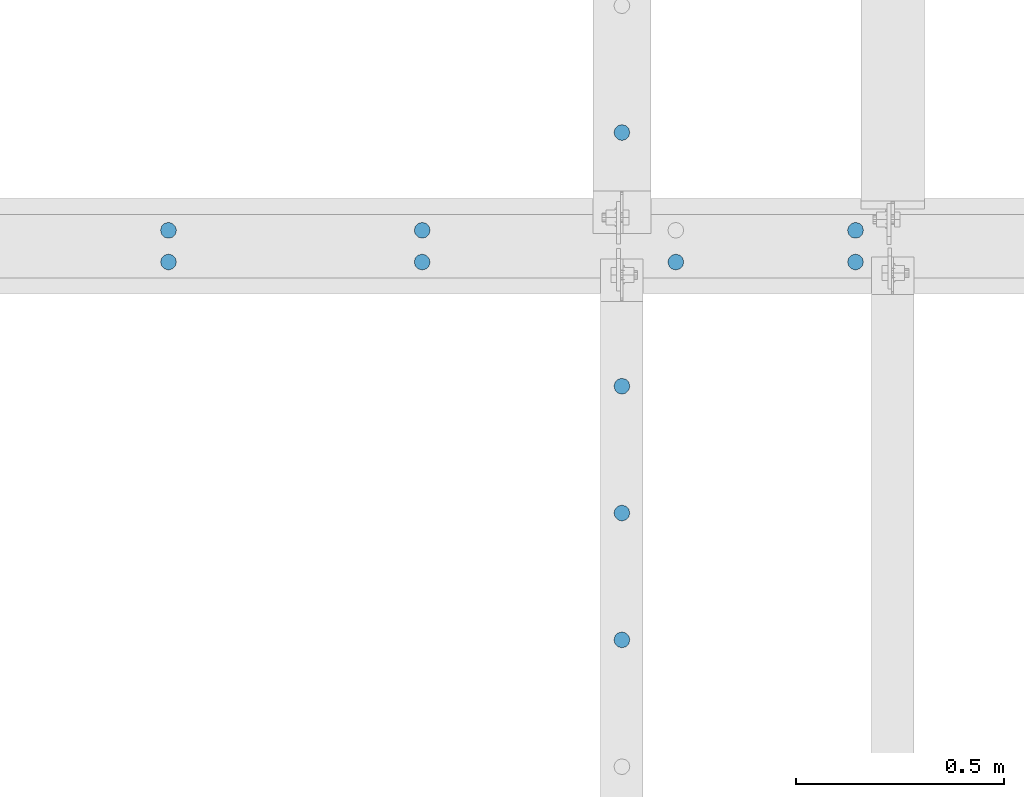
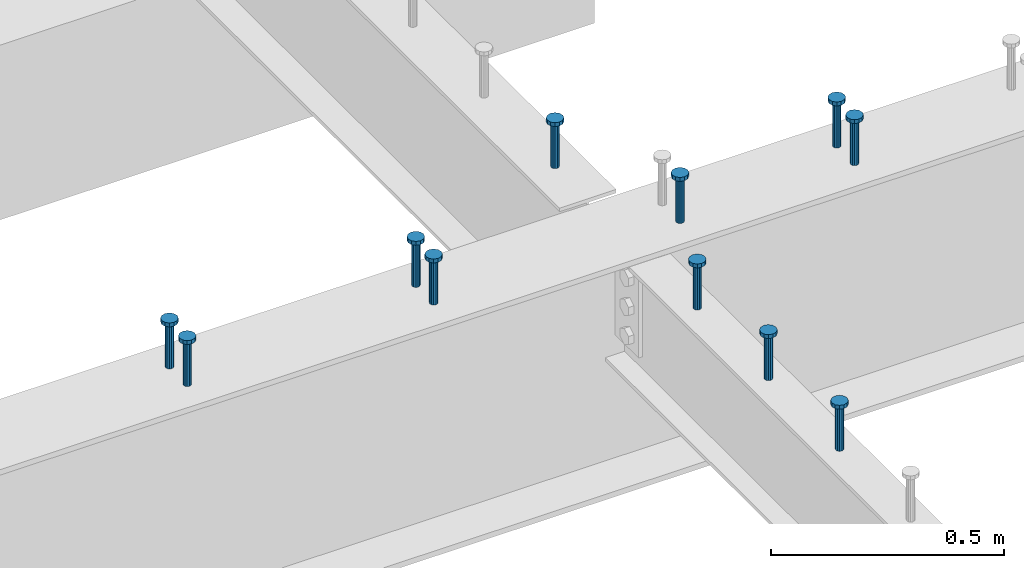
# One storey, part 153 of 975: 11 columns.
"""IFC2X3 building model written with IfcOpenShell, lengths in millimetres."""

from ifc_helpers import new_model, si_unit, frame, origin_with_axes, place, context, subcontext, project, spatial, faceted_brep, material, type_object, element, save


model = new_model("IFC2X3")

# Units and contexts
model_context = context("Model", 3, precision=1e-05, world=origin_with_axes())
body_context = subcontext(model_context, "Body", "Model", "MODEL_VIEW")
ifc_project = project(units=[si_unit("LENGTHUNIT", "METRE", prefix="MILLI"), si_unit("AREAUNIT", "SQUARE_METRE"), si_unit("VOLUMEUNIT", "CUBIC_METRE"), si_unit("MASSUNIT", "GRAM", prefix="KILO"), si_unit("TIMEUNIT", "SECOND"), si_unit("PLANEANGLEUNIT", "RADIAN"), si_unit("SOLIDANGLEUNIT", "STERADIAN"), si_unit("THERMODYNAMICTEMPERATUREUNIT", "DEGREE_CELSIUS"), si_unit("LUMINOUSINTENSITYUNIT", "LUMEN")], contexts=[model_context])

# Site, building, storey
site_placement = place(None, origin_with_axes())
site = spatial("IfcSite", under=ifc_project, at=site_placement, CompositionType="ELEMENT")
building_placement = place(site_placement, origin_with_axes())
building = spatial("IfcBuilding", under=site, at=building_placement, Name="Undefined", CompositionType="ELEMENT")
storey_placement = place(building_placement, origin_with_axes())
storey = spatial("IfcBuildingStorey", under=building, at=storey_placement, Name="Undefined", CompositionType="ELEMENT", Elevation=0.0)

# Columns
ifc_material = material(Name="STEEL/A108")
column_type = type_object("IfcColumnType", Name="STUD_3/4-DIA", PredefinedType="NOTDEFINED")
column_1_placement = place(storey_placement, frame((10858.5662704101, 6092.825, 3937.0), z_axis=(0.0, 1.0, 0.0), x_axis=(0.0, 0.0, 1.0)))
element("IfcColumn", 1, at=column_1_placement, inside=storey, type_object=column_type, material=ifc_material, ObjectType="STUD_3/4-DIA", context=body_context, shape_type="Brep", body=[
    faceted_brep([(0.0, -9.52000045776367, 0.0), (0.0, -8.25, -4.76000022888184), (115.57, -8.25, -4.76000022888184), (115.57, -9.52000045776367, 0.0), (0.0, -4.76000022888184, -8.25), (115.57, -4.76000022888184, -8.25), (0.0, 0.0, -9.52000045776367), (115.57, 0.0, -9.52000045776367), (0.0, 4.76000022888184, -8.25), (115.57, 4.76000022888184, -8.25), (0.0, 8.25, -4.76000022888184), (115.57, 8.25, -4.76000022888184), (0.0, 9.52000045776367, 0.0), (115.57, 9.52000045776367, 0.0), (0.0, 8.25, 4.76000022888184), (115.57, 8.25, 4.76000022888184), (0.0, 4.76000022888184, 8.25), (115.57, 4.76000022888184, 8.25), (0.0, 0.0, 9.52000045776367), (115.57, 0.0, 9.52000045776367), (0.0, -4.76000022888184, 8.25), (115.57, -4.76000022888184, 8.25), (0.0, -8.25, 4.76000022888184), (115.57, -8.25, 4.76000022888184), (116.84, -16.5, -9.52000045776367), (116.84, -19.0499992370605, 0.0), (116.84, -9.52000045776367, -16.5), (116.84, 0.0, -19.0499992370605), (116.84, 9.52000045776367, -16.5), (116.84, 16.5, -9.52000045776367), (116.84, 19.0499992370605, 0.0), (116.84, 16.5, 9.52000045776367), (116.84, 9.52000045776367, 16.5), (116.84, 0.0, 19.0499992370605), (116.84, -9.52000045776367, 16.5), (116.84, -16.5, 9.52000045776367), (127.0, -16.5, -9.52000045776367), (127.0, -19.0499992370605, 0.0), (127.0, -9.52000045776367, -16.5), (127.0, 0.0, -19.0499992370605), (127.0, 9.52000045776367, -16.5), (127.0, 16.5, -9.52000045776367), (127.0, 19.0499992370605, 0.0), (127.0, 16.5, 9.52000045776367), (127.0, 9.52000045776367, 16.5), (127.0, 0.0, 19.0499992370605), (127.0, -9.52000045776367, 16.5), (127.0, -16.5, 9.52000045776367)], [[[0, 1, 2, 3]], [[1, 4, 5, 2]], [[4, 6, 7, 5]], [[6, 8, 9, 7]], [[8, 10, 11, 9]], [[10, 12, 13, 11]], [[12, 14, 15, 13]], [[14, 16, 17, 15]], [[16, 18, 19, 17]], [[18, 20, 21, 19]], [[20, 22, 23, 21]], [[22, 0, 3, 23]], [[22, 20, 18, 16, 14, 12, 10, 8, 6, 4, 1, 0]], [[3, 2, 24, 25]], [[2, 5, 26, 24]], [[5, 7, 27, 26]], [[7, 9, 28, 27]], [[9, 11, 29, 28]], [[11, 13, 30, 29]], [[13, 15, 31, 30]], [[15, 17, 32, 31]], [[17, 19, 33, 32]], [[19, 21, 34, 33]], [[21, 23, 35, 34]], [[23, 3, 25, 35]], [[25, 24, 36, 37]], [[24, 26, 38, 36]], [[26, 27, 39, 38]], [[27, 28, 40, 39]], [[28, 29, 41, 40]], [[29, 30, 42, 41]], [[30, 31, 43, 42]], [[31, 32, 44, 43]], [[32, 33, 45, 44]], [[33, 34, 46, 45]], [[34, 35, 47, 46]], [[35, 25, 37, 47]], [[38, 39, 40, 41, 42, 43, 44, 45, 46, 47, 37, 36]]]),
])
column_2_placement = place(storey_placement, frame((10858.5662704101, 4873.625, 3937.0), z_axis=(0.0, 1.0, 0.0), x_axis=(0.0, 0.0, 1.0)))
element("IfcColumn", 2, at=column_2_placement, inside=storey, type_object=column_type, material=ifc_material, ObjectType="STUD_3/4-DIA", context=body_context, shape_type="Brep", body=[
    faceted_brep([(0.0, -9.52000045776367, 0.0), (0.0, -8.25, -4.76000022888184), (115.57, -8.25, -4.76000022888184), (115.57, -9.52000045776367, 0.0), (0.0, -4.76000022888184, -8.25), (115.57, -4.76000022888184, -8.25), (0.0, 0.0, -9.52000045776367), (115.57, 0.0, -9.52000045776367), (0.0, 4.76000022888184, -8.25), (115.57, 4.76000022888184, -8.25), (0.0, 8.25, -4.76000022888184), (115.57, 8.25, -4.76000022888184), (0.0, 9.52000045776367, 0.0), (115.57, 9.52000045776367, 0.0), (0.0, 8.25, 4.76000022888184), (115.57, 8.25, 4.76000022888184), (0.0, 4.76000022888184, 8.25), (115.57, 4.76000022888184, 8.25), (0.0, 0.0, 9.52000045776367), (115.57, 0.0, 9.52000045776367), (0.0, -4.76000022888184, 8.25), (115.57, -4.76000022888184, 8.25), (0.0, -8.25, 4.76000022888184), (115.57, -8.25, 4.76000022888184), (116.84, -16.5, -9.52000045776367), (116.84, -19.0499992370605, 0.0), (116.84, -9.52000045776367, -16.5), (116.84, 0.0, -19.0499992370605), (116.84, 9.52000045776367, -16.5), (116.84, 16.5, -9.52000045776367), (116.84, 19.0499992370605, 0.0), (116.84, 16.5, 9.52000045776367), (116.84, 9.52000045776367, 16.5), (116.84, 0.0, 19.0499992370605), (116.84, -9.52000045776367, 16.5), (116.84, -16.5, 9.52000045776367), (127.0, -16.5, -9.52000045776367), (127.0, -19.0499992370605, 0.0), (127.0, -9.52000045776367, -16.5), (127.0, 0.0, -19.0499992370605), (127.0, 9.52000045776367, -16.5), (127.0, 16.5, -9.52000045776367), (127.0, 19.0499992370605, 0.0), (127.0, 16.5, 9.52000045776367), (127.0, 9.52000045776367, 16.5), (127.0, 0.0, 19.0499992370605), (127.0, -9.52000045776367, 16.5), (127.0, -16.5, 9.52000045776367)], [[[0, 1, 2, 3]], [[1, 4, 5, 2]], [[4, 6, 7, 5]], [[6, 8, 9, 7]], [[8, 10, 11, 9]], [[10, 12, 13, 11]], [[12, 14, 15, 13]], [[14, 16, 17, 15]], [[16, 18, 19, 17]], [[18, 20, 21, 19]], [[20, 22, 23, 21]], [[22, 0, 3, 23]], [[22, 20, 18, 16, 14, 12, 10, 8, 6, 4, 1, 0]], [[3, 2, 24, 25]], [[2, 5, 26, 24]], [[5, 7, 27, 26]], [[7, 9, 28, 27]], [[9, 11, 29, 28]], [[11, 13, 30, 29]], [[13, 15, 31, 30]], [[15, 17, 32, 31]], [[17, 19, 33, 32]], [[19, 21, 34, 33]], [[21, 23, 35, 34]], [[23, 3, 25, 35]], [[25, 24, 36, 37]], [[24, 26, 38, 36]], [[26, 27, 39, 38]], [[27, 28, 40, 39]], [[28, 29, 41, 40]], [[29, 30, 42, 41]], [[30, 31, 43, 42]], [[31, 32, 44, 43]], [[32, 33, 45, 44]], [[33, 34, 46, 45]], [[34, 35, 47, 46]], [[35, 25, 37, 47]], [[38, 39, 40, 41, 42, 43, 44, 45, 46, 47, 37, 36]]]),
])
column_3_placement = place(storey_placement, frame((10858.5662704101, 5178.425, 3937.0), z_axis=(0.0, 1.0, 0.0), x_axis=(0.0, 0.0, 1.0)))
element("IfcColumn", 3, at=column_3_placement, inside=storey, type_object=column_type, material=ifc_material, ObjectType="STUD_3/4-DIA", context=body_context, shape_type="Brep", body=[
    faceted_brep([(0.0, -9.52000045776367, 0.0), (0.0, -8.25, -4.76000022888184), (115.57, -8.25, -4.76000022888184), (115.57, -9.52000045776367, 0.0), (0.0, -4.76000022888184, -8.25), (115.57, -4.76000022888184, -8.25), (0.0, 0.0, -9.52000045776367), (115.57, 0.0, -9.52000045776367), (0.0, 4.76000022888184, -8.25), (115.57, 4.76000022888184, -8.25), (0.0, 8.25, -4.76000022888184), (115.57, 8.25, -4.76000022888184), (0.0, 9.52000045776367, 0.0), (115.57, 9.52000045776367, 0.0), (0.0, 8.25, 4.76000022888184), (115.57, 8.25, 4.76000022888184), (0.0, 4.76000022888184, 8.25), (115.57, 4.76000022888184, 8.25), (0.0, 0.0, 9.52000045776367), (115.57, 0.0, 9.52000045776367), (0.0, -4.76000022888184, 8.25), (115.57, -4.76000022888184, 8.25), (0.0, -8.25, 4.76000022888184), (115.57, -8.25, 4.76000022888184), (116.84, -16.5, -9.52000045776367), (116.84, -19.0499992370605, 0.0), (116.84, -9.52000045776367, -16.5), (116.84, 0.0, -19.0499992370605), (116.84, 9.52000045776367, -16.5), (116.84, 16.5, -9.52000045776367), (116.84, 19.0499992370605, 0.0), (116.84, 16.5, 9.52000045776367), (116.84, 9.52000045776367, 16.5), (116.84, 0.0, 19.0499992370605), (116.84, -9.52000045776367, 16.5), (116.84, -16.5, 9.52000045776367), (127.0, -16.5, -9.52000045776367), (127.0, -19.0499992370605, 0.0), (127.0, -9.52000045776367, -16.5), (127.0, 0.0, -19.0499992370605), (127.0, 9.52000045776367, -16.5), (127.0, 16.5, -9.52000045776367), (127.0, 19.0499992370605, 0.0), (127.0, 16.5, 9.52000045776367), (127.0, 9.52000045776367, 16.5), (127.0, 0.0, 19.0499992370605), (127.0, -9.52000045776367, 16.5), (127.0, -16.5, 9.52000045776367)], [[[0, 1, 2, 3]], [[1, 4, 5, 2]], [[4, 6, 7, 5]], [[6, 8, 9, 7]], [[8, 10, 11, 9]], [[10, 12, 13, 11]], [[12, 14, 15, 13]], [[14, 16, 17, 15]], [[16, 18, 19, 17]], [[18, 20, 21, 19]], [[20, 22, 23, 21]], [[22, 0, 3, 23]], [[22, 20, 18, 16, 14, 12, 10, 8, 6, 4, 1, 0]], [[3, 2, 24, 25]], [[2, 5, 26, 24]], [[5, 7, 27, 26]], [[7, 9, 28, 27]], [[9, 11, 29, 28]], [[11, 13, 30, 29]], [[13, 15, 31, 30]], [[15, 17, 32, 31]], [[17, 19, 33, 32]], [[19, 21, 34, 33]], [[21, 23, 35, 34]], [[23, 3, 25, 35]], [[25, 24, 36, 37]], [[24, 26, 38, 36]], [[26, 27, 39, 38]], [[27, 28, 40, 39]], [[28, 29, 41, 40]], [[29, 30, 42, 41]], [[30, 31, 43, 42]], [[31, 32, 44, 43]], [[32, 33, 45, 44]], [[33, 34, 46, 45]], [[34, 35, 47, 46]], [[35, 25, 37, 47]], [[38, 39, 40, 41, 42, 43, 44, 45, 46, 47, 37, 36]]]),
])
column_4_placement = place(storey_placement, frame((10858.5662704101, 5483.225, 3937.0), z_axis=(0.0, 1.0, 0.0), x_axis=(0.0, 0.0, 1.0)))
element("IfcColumn", 4, at=column_4_placement, inside=storey, type_object=column_type, material=ifc_material, ObjectType="STUD_3/4-DIA", context=body_context, shape_type="Brep", body=[
    faceted_brep([(0.0, -9.52000045776367, 0.0), (0.0, -8.25, -4.76000022888184), (115.57, -8.25, -4.76000022888184), (115.57, -9.52000045776367, 0.0), (0.0, -4.76000022888184, -8.25), (115.57, -4.76000022888184, -8.25), (0.0, 0.0, -9.52000045776367), (115.57, 0.0, -9.52000045776367), (0.0, 4.76000022888184, -8.25), (115.57, 4.76000022888184, -8.25), (0.0, 8.25, -4.76000022888184), (115.57, 8.25, -4.76000022888184), (0.0, 9.52000045776367, 0.0), (115.57, 9.52000045776367, 0.0), (0.0, 8.25, 4.76000022888184), (115.57, 8.25, 4.76000022888184), (0.0, 4.76000022888184, 8.25), (115.57, 4.76000022888184, 8.25), (0.0, 0.0, 9.52000045776367), (115.57, 0.0, 9.52000045776367), (0.0, -4.76000022888184, 8.25), (115.57, -4.76000022888184, 8.25), (0.0, -8.25, 4.76000022888184), (115.57, -8.25, 4.76000022888184), (116.84, -16.5, -9.52000045776367), (116.84, -19.0499992370605, 0.0), (116.84, -9.52000045776367, -16.5), (116.84, 0.0, -19.0499992370605), (116.84, 9.52000045776367, -16.5), (116.84, 16.5, -9.52000045776367), (116.84, 19.0499992370605, 0.0), (116.84, 16.5, 9.52000045776367), (116.84, 9.52000045776367, 16.5), (116.84, 0.0, 19.0499992370605), (116.84, -9.52000045776367, 16.5), (116.84, -16.5, 9.52000045776367), (127.0, -16.5, -9.52000045776367), (127.0, -19.0499992370605, 0.0), (127.0, -9.52000045776367, -16.5), (127.0, 0.0, -19.0499992370605), (127.0, 9.52000045776367, -16.5), (127.0, 16.5, -9.52000045776367), (127.0, 19.0499992370605, 0.0), (127.0, 16.5, 9.52000045776367), (127.0, 9.52000045776367, 16.5), (127.0, 0.0, 19.0499992370605), (127.0, -9.52000045776367, 16.5), (127.0, -16.5, 9.52000045776367)], [[[0, 1, 2, 3]], [[1, 4, 5, 2]], [[4, 6, 7, 5]], [[6, 8, 9, 7]], [[8, 10, 11, 9]], [[10, 12, 13, 11]], [[12, 14, 15, 13]], [[14, 16, 17, 15]], [[16, 18, 19, 17]], [[18, 20, 21, 19]], [[20, 22, 23, 21]], [[22, 0, 3, 23]], [[22, 20, 18, 16, 14, 12, 10, 8, 6, 4, 1, 0]], [[3, 2, 24, 25]], [[2, 5, 26, 24]], [[5, 7, 27, 26]], [[7, 9, 28, 27]], [[9, 11, 29, 28]], [[11, 13, 30, 29]], [[13, 15, 31, 30]], [[15, 17, 32, 31]], [[17, 19, 33, 32]], [[19, 21, 34, 33]], [[21, 23, 35, 34]], [[23, 3, 25, 35]], [[25, 24, 36, 37]], [[24, 26, 38, 36]], [[26, 27, 39, 38]], [[27, 28, 40, 39]], [[28, 29, 41, 40]], [[29, 30, 42, 41]], [[30, 31, 43, 42]], [[31, 32, 44, 43]], [[32, 33, 45, 44]], [[33, 34, 46, 45]], [[34, 35, 47, 46]], [[35, 25, 37, 47]], [[38, 39, 40, 41, 42, 43, 44, 45, 46, 47, 37, 36]]]),
])
column_5_placement = place(storey_placement, frame((11419.9459584101, 5781.675, 3937.0), z_axis=(0.0, 1.0, 0.0), x_axis=(0.0, 0.0, 1.0)))
element("IfcColumn", 5, at=column_5_placement, inside=storey, type_object=column_type, material=ifc_material, ObjectType="STUD_3/4-DIA", context=body_context, shape_type="Brep", body=[
    faceted_brep([(0.0, -9.52000045776367, 0.0), (0.0, -8.25, -4.76000022888184), (115.57, -8.25, -4.76000022888184), (115.57, -9.52000045776367, 0.0), (0.0, -4.76000022888184, -8.25), (115.57, -4.76000022888184, -8.25), (0.0, 0.0, -9.52000045776367), (115.57, 0.0, -9.52000045776367), (0.0, 4.76000022888184, -8.25), (115.57, 4.76000022888184, -8.25), (0.0, 8.25, -4.76000022888184), (115.57, 8.25, -4.76000022888184), (0.0, 9.52000045776367, 0.0), (115.57, 9.52000045776367, 0.0), (0.0, 8.25, 4.76000022888184), (115.57, 8.25, 4.76000022888184), (0.0, 4.76000022888184, 8.25), (115.57, 4.76000022888184, 8.25), (0.0, 0.0, 9.52000045776367), (115.57, 0.0, 9.52000045776367), (0.0, -4.76000022888184, 8.25), (115.57, -4.76000022888184, 8.25), (0.0, -8.25, 4.76000022888184), (115.57, -8.25, 4.76000022888184), (116.84, -16.5, -9.52000045776367), (116.84, -19.0499992370605, 0.0), (116.84, -9.52000045776367, -16.5), (116.84, 0.0, -19.0499992370605), (116.84, 9.52000045776367, -16.5), (116.84, 16.5, -9.52000045776367), (116.84, 19.0499992370605, 0.0), (116.84, 16.5, 9.52000045776367), (116.84, 9.52000045776367, 16.5), (116.84, 0.0, 19.0499992370605), (116.84, -9.52000045776367, 16.5), (116.84, -16.5, 9.52000045776367), (127.0, -16.5, -9.52000045776367), (127.0, -19.0499992370605, 0.0), (127.0, -9.52000045776367, -16.5), (127.0, 0.0, -19.0499992370605), (127.0, 9.52000045776367, -16.5), (127.0, 16.5, -9.52000045776367), (127.0, 19.0499992370605, 0.0), (127.0, 16.5, 9.52000045776367), (127.0, 9.52000045776367, 16.5), (127.0, 0.0, 19.0499992370605), (127.0, -9.52000045776367, 16.5), (127.0, -16.5, 9.52000045776367)], [[[0, 1, 2, 3]], [[1, 4, 5, 2]], [[4, 6, 7, 5]], [[6, 8, 9, 7]], [[8, 10, 11, 9]], [[10, 12, 13, 11]], [[12, 14, 15, 13]], [[14, 16, 17, 15]], [[16, 18, 19, 17]], [[18, 20, 21, 19]], [[20, 22, 23, 21]], [[22, 0, 3, 23]], [[22, 20, 18, 16, 14, 12, 10, 8, 6, 4, 1, 0]], [[3, 2, 24, 25]], [[2, 5, 26, 24]], [[5, 7, 27, 26]], [[7, 9, 28, 27]], [[9, 11, 29, 28]], [[11, 13, 30, 29]], [[13, 15, 31, 30]], [[15, 17, 32, 31]], [[17, 19, 33, 32]], [[19, 21, 34, 33]], [[21, 23, 35, 34]], [[23, 3, 25, 35]], [[25, 24, 36, 37]], [[24, 26, 38, 36]], [[26, 27, 39, 38]], [[27, 28, 40, 39]], [[28, 29, 41, 40]], [[29, 30, 42, 41]], [[30, 31, 43, 42]], [[31, 32, 44, 43]], [[32, 33, 45, 44]], [[33, 34, 46, 45]], [[34, 35, 47, 46]], [[35, 25, 37, 47]], [[38, 39, 40, 41, 42, 43, 44, 45, 46, 47, 37, 36]]]),
])
column_6_placement = place(storey_placement, frame((11419.9459584101, 5857.875, 3937.0), z_axis=(0.0, 1.0, 0.0), x_axis=(0.0, 0.0, 1.0)))
element("IfcColumn", 6, at=column_6_placement, inside=storey, type_object=column_type, material=ifc_material, ObjectType="STUD_3/4-DIA", context=body_context, shape_type="Brep", body=[
    faceted_brep([(0.0, -9.52000045776367, 0.0), (0.0, -8.25, -4.76000022888184), (115.57, -8.25, -4.76000022888184), (115.57, -9.52000045776367, 0.0), (0.0, -4.76000022888184, -8.25), (115.57, -4.76000022888184, -8.25), (0.0, 0.0, -9.52000045776367), (115.57, 0.0, -9.52000045776367), (0.0, 4.76000022888184, -8.25), (115.57, 4.76000022888184, -8.25), (0.0, 8.25, -4.76000022888184), (115.57, 8.25, -4.76000022888184), (0.0, 9.52000045776367, 0.0), (115.57, 9.52000045776367, 0.0), (0.0, 8.25, 4.76000022888184), (115.57, 8.25, 4.76000022888184), (0.0, 4.76000022888184, 8.25), (115.57, 4.76000022888184, 8.25), (0.0, 0.0, 9.52000045776367), (115.57, 0.0, 9.52000045776367), (0.0, -4.76000022888184, 8.25), (115.57, -4.76000022888184, 8.25), (0.0, -8.25, 4.76000022888184), (115.57, -8.25, 4.76000022888184), (116.84, -16.5, -9.52000045776367), (116.84, -19.0499992370605, 0.0), (116.84, -9.52000045776367, -16.5), (116.84, 0.0, -19.0499992370605), (116.84, 9.52000045776367, -16.5), (116.84, 16.5, -9.52000045776367), (116.84, 19.0499992370605, 0.0), (116.84, 16.5, 9.52000045776367), (116.84, 9.52000045776367, 16.5), (116.84, 0.0, 19.0499992370605), (116.84, -9.52000045776367, 16.5), (116.84, -16.5, 9.52000045776367), (127.0, -16.5, -9.52000045776367), (127.0, -19.0499992370605, 0.0), (127.0, -9.52000045776367, -16.5), (127.0, 0.0, -19.0499992370605), (127.0, 9.52000045776367, -16.5), (127.0, 16.5, -9.52000045776367), (127.0, 19.0499992370605, 0.0), (127.0, 16.5, 9.52000045776367), (127.0, 9.52000045776367, 16.5), (127.0, 0.0, 19.0499992370605), (127.0, -9.52000045776367, 16.5), (127.0, -16.5, 9.52000045776367)], [[[0, 1, 2, 3]], [[1, 4, 5, 2]], [[4, 6, 7, 5]], [[6, 8, 9, 7]], [[8, 10, 11, 9]], [[10, 12, 13, 11]], [[12, 14, 15, 13]], [[14, 16, 17, 15]], [[16, 18, 19, 17]], [[18, 20, 21, 19]], [[20, 22, 23, 21]], [[22, 0, 3, 23]], [[22, 20, 18, 16, 14, 12, 10, 8, 6, 4, 1, 0]], [[3, 2, 24, 25]], [[2, 5, 26, 24]], [[5, 7, 27, 26]], [[7, 9, 28, 27]], [[9, 11, 29, 28]], [[11, 13, 30, 29]], [[13, 15, 31, 30]], [[15, 17, 32, 31]], [[17, 19, 33, 32]], [[19, 21, 34, 33]], [[21, 23, 35, 34]], [[23, 3, 25, 35]], [[25, 24, 36, 37]], [[24, 26, 38, 36]], [[26, 27, 39, 38]], [[27, 28, 40, 39]], [[28, 29, 41, 40]], [[29, 30, 42, 41]], [[30, 31, 43, 42]], [[31, 32, 44, 43]], [[32, 33, 45, 44]], [[33, 34, 46, 45]], [[34, 35, 47, 46]], [[35, 25, 37, 47]], [[38, 39, 40, 41, 42, 43, 44, 45, 46, 47, 37, 36]]]),
])
column_7_placement = place(storey_placement, frame((10988.1459584101, 5781.675, 3937.0), z_axis=(0.0, 1.0, 0.0), x_axis=(0.0, 0.0, 1.0)))
element("IfcColumn", 7, at=column_7_placement, inside=storey, type_object=column_type, material=ifc_material, ObjectType="STUD_3/4-DIA", context=body_context, shape_type="Brep", body=[
    faceted_brep([(0.0, -9.52000045776367, 0.0), (0.0, -8.25, -4.76000022888184), (115.57, -8.25, -4.76000022888184), (115.57, -9.52000045776367, 0.0), (0.0, -4.76000022888184, -8.25), (115.57, -4.76000022888184, -8.25), (0.0, 0.0, -9.52000045776367), (115.57, 0.0, -9.52000045776367), (0.0, 4.76000022888184, -8.25), (115.57, 4.76000022888184, -8.25), (0.0, 8.25, -4.76000022888184), (115.57, 8.25, -4.76000022888184), (0.0, 9.52000045776367, 0.0), (115.57, 9.52000045776367, 0.0), (0.0, 8.25, 4.76000022888184), (115.57, 8.25, 4.76000022888184), (0.0, 4.76000022888184, 8.25), (115.57, 4.76000022888184, 8.25), (0.0, 0.0, 9.52000045776367), (115.57, 0.0, 9.52000045776367), (0.0, -4.76000022888184, 8.25), (115.57, -4.76000022888184, 8.25), (0.0, -8.25, 4.76000022888184), (115.57, -8.25, 4.76000022888184), (116.84, -16.5, -9.52000045776367), (116.84, -19.0499992370605, 0.0), (116.84, -9.52000045776367, -16.5), (116.84, 0.0, -19.0499992370605), (116.84, 9.52000045776367, -16.5), (116.84, 16.5, -9.52000045776367), (116.84, 19.0499992370605, 0.0), (116.84, 16.5, 9.52000045776367), (116.84, 9.52000045776367, 16.5), (116.84, 0.0, 19.0499992370605), (116.84, -9.52000045776367, 16.5), (116.84, -16.5, 9.52000045776367), (127.0, -16.5, -9.52000045776367), (127.0, -19.0499992370605, 0.0), (127.0, -9.52000045776367, -16.5), (127.0, 0.0, -19.0499992370605), (127.0, 9.52000045776367, -16.5), (127.0, 16.5, -9.52000045776367), (127.0, 19.0499992370605, 0.0), (127.0, 16.5, 9.52000045776367), (127.0, 9.52000045776367, 16.5), (127.0, 0.0, 19.0499992370605), (127.0, -9.52000045776367, 16.5), (127.0, -16.5, 9.52000045776367)], [[[0, 1, 2, 3]], [[1, 4, 5, 2]], [[4, 6, 7, 5]], [[6, 8, 9, 7]], [[8, 10, 11, 9]], [[10, 12, 13, 11]], [[12, 14, 15, 13]], [[14, 16, 17, 15]], [[16, 18, 19, 17]], [[18, 20, 21, 19]], [[20, 22, 23, 21]], [[22, 0, 3, 23]], [[22, 20, 18, 16, 14, 12, 10, 8, 6, 4, 1, 0]], [[3, 2, 24, 25]], [[2, 5, 26, 24]], [[5, 7, 27, 26]], [[7, 9, 28, 27]], [[9, 11, 29, 28]], [[11, 13, 30, 29]], [[13, 15, 31, 30]], [[15, 17, 32, 31]], [[17, 19, 33, 32]], [[19, 21, 34, 33]], [[21, 23, 35, 34]], [[23, 3, 25, 35]], [[25, 24, 36, 37]], [[24, 26, 38, 36]], [[26, 27, 39, 38]], [[27, 28, 40, 39]], [[28, 29, 41, 40]], [[29, 30, 42, 41]], [[30, 31, 43, 42]], [[31, 32, 44, 43]], [[32, 33, 45, 44]], [[33, 34, 46, 45]], [[34, 35, 47, 46]], [[35, 25, 37, 47]], [[38, 39, 40, 41, 42, 43, 44, 45, 46, 47, 37, 36]]]),
])
column_8_placement = place(storey_placement, frame((10378.5459584101, 5781.675, 3937.0), z_axis=(0.0, 1.0, 0.0), x_axis=(0.0, 0.0, 1.0)))
element("IfcColumn", 8, at=column_8_placement, inside=storey, type_object=column_type, material=ifc_material, ObjectType="STUD_3/4-DIA", context=body_context, shape_type="Brep", body=[
    faceted_brep([(0.0, -9.52000045776367, 0.0), (0.0, -8.25, -4.76000022888184), (115.57, -8.25, -4.76000022888184), (115.57, -9.52000045776367, 0.0), (0.0, -4.76000022888184, -8.25), (115.57, -4.76000022888184, -8.25), (0.0, 0.0, -9.52000045776367), (115.57, 0.0, -9.52000045776367), (0.0, 4.76000022888184, -8.25), (115.57, 4.76000022888184, -8.25), (0.0, 8.25, -4.76000022888184), (115.57, 8.25, -4.76000022888184), (0.0, 9.52000045776367, 0.0), (115.57, 9.52000045776367, 0.0), (0.0, 8.25, 4.76000022888184), (115.57, 8.25, 4.76000022888184), (0.0, 4.76000022888184, 8.25), (115.57, 4.76000022888184, 8.25), (0.0, 0.0, 9.52000045776367), (115.57, 0.0, 9.52000045776367), (0.0, -4.76000022888184, 8.25), (115.57, -4.76000022888184, 8.25), (0.0, -8.25, 4.76000022888184), (115.57, -8.25, 4.76000022888184), (116.84, -16.5, -9.52000045776367), (116.84, -19.0499992370605, 0.0), (116.84, -9.52000045776367, -16.5), (116.84, 0.0, -19.0499992370605), (116.84, 9.52000045776367, -16.5), (116.84, 16.5, -9.52000045776367), (116.84, 19.0499992370605, 0.0), (116.84, 16.5, 9.52000045776367), (116.84, 9.52000045776367, 16.5), (116.84, 0.0, 19.0499992370605), (116.84, -9.52000045776367, 16.5), (116.84, -16.5, 9.52000045776367), (127.0, -16.5, -9.52000045776367), (127.0, -19.0499992370605, 0.0), (127.0, -9.52000045776367, -16.5), (127.0, 0.0, -19.0499992370605), (127.0, 9.52000045776367, -16.5), (127.0, 16.5, -9.52000045776367), (127.0, 19.0499992370605, 0.0), (127.0, 16.5, 9.52000045776367), (127.0, 9.52000045776367, 16.5), (127.0, 0.0, 19.0499992370605), (127.0, -9.52000045776367, 16.5), (127.0, -16.5, 9.52000045776367)], [[[0, 1, 2, 3]], [[1, 4, 5, 2]], [[4, 6, 7, 5]], [[6, 8, 9, 7]], [[8, 10, 11, 9]], [[10, 12, 13, 11]], [[12, 14, 15, 13]], [[14, 16, 17, 15]], [[16, 18, 19, 17]], [[18, 20, 21, 19]], [[20, 22, 23, 21]], [[22, 0, 3, 23]], [[22, 20, 18, 16, 14, 12, 10, 8, 6, 4, 1, 0]], [[3, 2, 24, 25]], [[2, 5, 26, 24]], [[5, 7, 27, 26]], [[7, 9, 28, 27]], [[9, 11, 29, 28]], [[11, 13, 30, 29]], [[13, 15, 31, 30]], [[15, 17, 32, 31]], [[17, 19, 33, 32]], [[19, 21, 34, 33]], [[21, 23, 35, 34]], [[23, 3, 25, 35]], [[25, 24, 36, 37]], [[24, 26, 38, 36]], [[26, 27, 39, 38]], [[27, 28, 40, 39]], [[28, 29, 41, 40]], [[29, 30, 42, 41]], [[30, 31, 43, 42]], [[31, 32, 44, 43]], [[32, 33, 45, 44]], [[33, 34, 46, 45]], [[34, 35, 47, 46]], [[35, 25, 37, 47]], [[38, 39, 40, 41, 42, 43, 44, 45, 46, 47, 37, 36]]]),
])
column_9_placement = place(storey_placement, frame((10378.5459584101, 5857.875, 3937.0), z_axis=(0.0, 1.0, 0.0), x_axis=(0.0, 0.0, 1.0)))
element("IfcColumn", 9, at=column_9_placement, inside=storey, type_object=column_type, material=ifc_material, ObjectType="STUD_3/4-DIA", context=body_context, shape_type="Brep", body=[
    faceted_brep([(0.0, -9.52000045776367, 0.0), (0.0, -8.25, -4.76000022888184), (115.57, -8.25, -4.76000022888184), (115.57, -9.52000045776367, 0.0), (0.0, -4.76000022888184, -8.25), (115.57, -4.76000022888184, -8.25), (0.0, 0.0, -9.52000045776367), (115.57, 0.0, -9.52000045776367), (0.0, 4.76000022888184, -8.25), (115.57, 4.76000022888184, -8.25), (0.0, 8.25, -4.76000022888184), (115.57, 8.25, -4.76000022888184), (0.0, 9.52000045776367, 0.0), (115.57, 9.52000045776367, 0.0), (0.0, 8.25, 4.76000022888184), (115.57, 8.25, 4.76000022888184), (0.0, 4.76000022888184, 8.25), (115.57, 4.76000022888184, 8.25), (0.0, 0.0, 9.52000045776367), (115.57, 0.0, 9.52000045776367), (0.0, -4.76000022888184, 8.25), (115.57, -4.76000022888184, 8.25), (0.0, -8.25, 4.76000022888184), (115.57, -8.25, 4.76000022888184), (116.84, -16.5, -9.52000045776367), (116.84, -19.0499992370605, 0.0), (116.84, -9.52000045776367, -16.5), (116.84, 0.0, -19.0499992370605), (116.84, 9.52000045776367, -16.5), (116.84, 16.5, -9.52000045776367), (116.84, 19.0499992370605, 0.0), (116.84, 16.5, 9.52000045776367), (116.84, 9.52000045776367, 16.5), (116.84, 0.0, 19.0499992370605), (116.84, -9.52000045776367, 16.5), (116.84, -16.5, 9.52000045776367), (127.0, -16.5, -9.52000045776367), (127.0, -19.0499992370605, 0.0), (127.0, -9.52000045776367, -16.5), (127.0, 0.0, -19.0499992370605), (127.0, 9.52000045776367, -16.5), (127.0, 16.5, -9.52000045776367), (127.0, 19.0499992370605, 0.0), (127.0, 16.5, 9.52000045776367), (127.0, 9.52000045776367, 16.5), (127.0, 0.0, 19.0499992370605), (127.0, -9.52000045776367, 16.5), (127.0, -16.5, 9.52000045776367)], [[[0, 1, 2, 3]], [[1, 4, 5, 2]], [[4, 6, 7, 5]], [[6, 8, 9, 7]], [[8, 10, 11, 9]], [[10, 12, 13, 11]], [[12, 14, 15, 13]], [[14, 16, 17, 15]], [[16, 18, 19, 17]], [[18, 20, 21, 19]], [[20, 22, 23, 21]], [[22, 0, 3, 23]], [[22, 20, 18, 16, 14, 12, 10, 8, 6, 4, 1, 0]], [[3, 2, 24, 25]], [[2, 5, 26, 24]], [[5, 7, 27, 26]], [[7, 9, 28, 27]], [[9, 11, 29, 28]], [[11, 13, 30, 29]], [[13, 15, 31, 30]], [[15, 17, 32, 31]], [[17, 19, 33, 32]], [[19, 21, 34, 33]], [[21, 23, 35, 34]], [[23, 3, 25, 35]], [[25, 24, 36, 37]], [[24, 26, 38, 36]], [[26, 27, 39, 38]], [[27, 28, 40, 39]], [[28, 29, 41, 40]], [[29, 30, 42, 41]], [[30, 31, 43, 42]], [[31, 32, 44, 43]], [[32, 33, 45, 44]], [[33, 34, 46, 45]], [[34, 35, 47, 46]], [[35, 25, 37, 47]], [[38, 39, 40, 41, 42, 43, 44, 45, 46, 47, 37, 36]]]),
])
column_10_placement = place(storey_placement, frame((9768.94595841015, 5781.675, 3937.0), z_axis=(0.0, 1.0, 0.0), x_axis=(0.0, 0.0, 1.0)))
element("IfcColumn", 10, at=column_10_placement, inside=storey, type_object=column_type, material=ifc_material, ObjectType="STUD_3/4-DIA", context=body_context, shape_type="Brep", body=[
    faceted_brep([(0.0, -9.52000045776367, 0.0), (0.0, -8.25, -4.76000022888184), (115.57, -8.25, -4.76000022888184), (115.57, -9.52000045776367, 0.0), (0.0, -4.76000022888184, -8.25), (115.57, -4.76000022888184, -8.25), (0.0, 0.0, -9.52000045776367), (115.57, 0.0, -9.52000045776367), (0.0, 4.76000022888184, -8.25), (115.57, 4.76000022888184, -8.25), (0.0, 8.25, -4.76000022888184), (115.57, 8.25, -4.76000022888184), (0.0, 9.52000045776367, 0.0), (115.57, 9.52000045776367, 0.0), (0.0, 8.25, 4.76000022888184), (115.57, 8.25, 4.76000022888184), (0.0, 4.76000022888184, 8.25), (115.57, 4.76000022888184, 8.25), (0.0, 0.0, 9.52000045776367), (115.57, 0.0, 9.52000045776367), (0.0, -4.76000022888184, 8.25), (115.57, -4.76000022888184, 8.25), (0.0, -8.25, 4.76000022888184), (115.57, -8.25, 4.76000022888184), (116.84, -16.5, -9.52000045776367), (116.84, -19.0499992370605, 0.0), (116.84, -9.52000045776367, -16.5), (116.84, 0.0, -19.0499992370605), (116.84, 9.52000045776367, -16.5), (116.84, 16.5, -9.52000045776367), (116.84, 19.0499992370605, 0.0), (116.84, 16.5, 9.52000045776367), (116.84, 9.52000045776367, 16.5), (116.84, 0.0, 19.0499992370605), (116.84, -9.52000045776367, 16.5), (116.84, -16.5, 9.52000045776367), (127.0, -16.5, -9.52000045776367), (127.0, -19.0499992370605, 0.0), (127.0, -9.52000045776367, -16.5), (127.0, 0.0, -19.0499992370605), (127.0, 9.52000045776367, -16.5), (127.0, 16.5, -9.52000045776367), (127.0, 19.0499992370605, 0.0), (127.0, 16.5, 9.52000045776367), (127.0, 9.52000045776367, 16.5), (127.0, 0.0, 19.0499992370605), (127.0, -9.52000045776367, 16.5), (127.0, -16.5, 9.52000045776367)], [[[0, 1, 2, 3]], [[1, 4, 5, 2]], [[4, 6, 7, 5]], [[6, 8, 9, 7]], [[8, 10, 11, 9]], [[10, 12, 13, 11]], [[12, 14, 15, 13]], [[14, 16, 17, 15]], [[16, 18, 19, 17]], [[18, 20, 21, 19]], [[20, 22, 23, 21]], [[22, 0, 3, 23]], [[22, 20, 18, 16, 14, 12, 10, 8, 6, 4, 1, 0]], [[3, 2, 24, 25]], [[2, 5, 26, 24]], [[5, 7, 27, 26]], [[7, 9, 28, 27]], [[9, 11, 29, 28]], [[11, 13, 30, 29]], [[13, 15, 31, 30]], [[15, 17, 32, 31]], [[17, 19, 33, 32]], [[19, 21, 34, 33]], [[21, 23, 35, 34]], [[23, 3, 25, 35]], [[25, 24, 36, 37]], [[24, 26, 38, 36]], [[26, 27, 39, 38]], [[27, 28, 40, 39]], [[28, 29, 41, 40]], [[29, 30, 42, 41]], [[30, 31, 43, 42]], [[31, 32, 44, 43]], [[32, 33, 45, 44]], [[33, 34, 46, 45]], [[34, 35, 47, 46]], [[35, 25, 37, 47]], [[38, 39, 40, 41, 42, 43, 44, 45, 46, 47, 37, 36]]]),
])
column_11_placement = place(storey_placement, frame((9768.94595841015, 5857.875, 3937.0), z_axis=(0.0, 1.0, 0.0), x_axis=(0.0, 0.0, 1.0)))
element("IfcColumn", 11, at=column_11_placement, inside=storey, type_object=column_type, material=ifc_material, ObjectType="STUD_3/4-DIA", context=body_context, shape_type="Brep", body=[
    faceted_brep([(0.0, -9.52000045776367, 0.0), (0.0, -8.25, -4.76000022888184), (115.57, -8.25, -4.76000022888184), (115.57, -9.52000045776367, 0.0), (0.0, -4.76000022888184, -8.25), (115.57, -4.76000022888184, -8.25), (0.0, 0.0, -9.52000045776367), (115.57, 0.0, -9.52000045776367), (0.0, 4.76000022888184, -8.25), (115.57, 4.76000022888184, -8.25), (0.0, 8.25, -4.76000022888184), (115.57, 8.25, -4.76000022888184), (0.0, 9.52000045776367, 0.0), (115.57, 9.52000045776367, 0.0), (0.0, 8.25, 4.76000022888184), (115.57, 8.25, 4.76000022888184), (0.0, 4.76000022888184, 8.25), (115.57, 4.76000022888184, 8.25), (0.0, 0.0, 9.52000045776367), (115.57, 0.0, 9.52000045776367), (0.0, -4.76000022888184, 8.25), (115.57, -4.76000022888184, 8.25), (0.0, -8.25, 4.76000022888184), (115.57, -8.25, 4.76000022888184), (116.84, -16.5, -9.52000045776367), (116.84, -19.0499992370605, 0.0), (116.84, -9.52000045776367, -16.5), (116.84, 0.0, -19.0499992370605), (116.84, 9.52000045776367, -16.5), (116.84, 16.5, -9.52000045776367), (116.84, 19.0499992370605, 0.0), (116.84, 16.5, 9.52000045776367), (116.84, 9.52000045776367, 16.5), (116.84, 0.0, 19.0499992370605), (116.84, -9.52000045776367, 16.5), (116.84, -16.5, 9.52000045776367), (127.0, -16.5, -9.52000045776367), (127.0, -19.0499992370605, 0.0), (127.0, -9.52000045776367, -16.5), (127.0, 0.0, -19.0499992370605), (127.0, 9.52000045776367, -16.5), (127.0, 16.5, -9.52000045776367), (127.0, 19.0499992370605, 0.0), (127.0, 16.5, 9.52000045776367), (127.0, 9.52000045776367, 16.5), (127.0, 0.0, 19.0499992370605), (127.0, -9.52000045776367, 16.5), (127.0, -16.5, 9.52000045776367)], [[[0, 1, 2, 3]], [[1, 4, 5, 2]], [[4, 6, 7, 5]], [[6, 8, 9, 7]], [[8, 10, 11, 9]], [[10, 12, 13, 11]], [[12, 14, 15, 13]], [[14, 16, 17, 15]], [[16, 18, 19, 17]], [[18, 20, 21, 19]], [[20, 22, 23, 21]], [[22, 0, 3, 23]], [[22, 20, 18, 16, 14, 12, 10, 8, 6, 4, 1, 0]], [[3, 2, 24, 25]], [[2, 5, 26, 24]], [[5, 7, 27, 26]], [[7, 9, 28, 27]], [[9, 11, 29, 28]], [[11, 13, 30, 29]], [[13, 15, 31, 30]], [[15, 17, 32, 31]], [[17, 19, 33, 32]], [[19, 21, 34, 33]], [[21, 23, 35, 34]], [[23, 3, 25, 35]], [[25, 24, 36, 37]], [[24, 26, 38, 36]], [[26, 27, 39, 38]], [[27, 28, 40, 39]], [[28, 29, 41, 40]], [[29, 30, 42, 41]], [[30, 31, 43, 42]], [[31, 32, 44, 43]], [[32, 33, 45, 44]], [[33, 34, 46, 45]], [[34, 35, 47, 46]], [[35, 25, 37, 47]], [[38, 39, 40, 41, 42, 43, 44, 45, 46, 47, 37, 36]]]),
])

save(model, "model.ifc")
